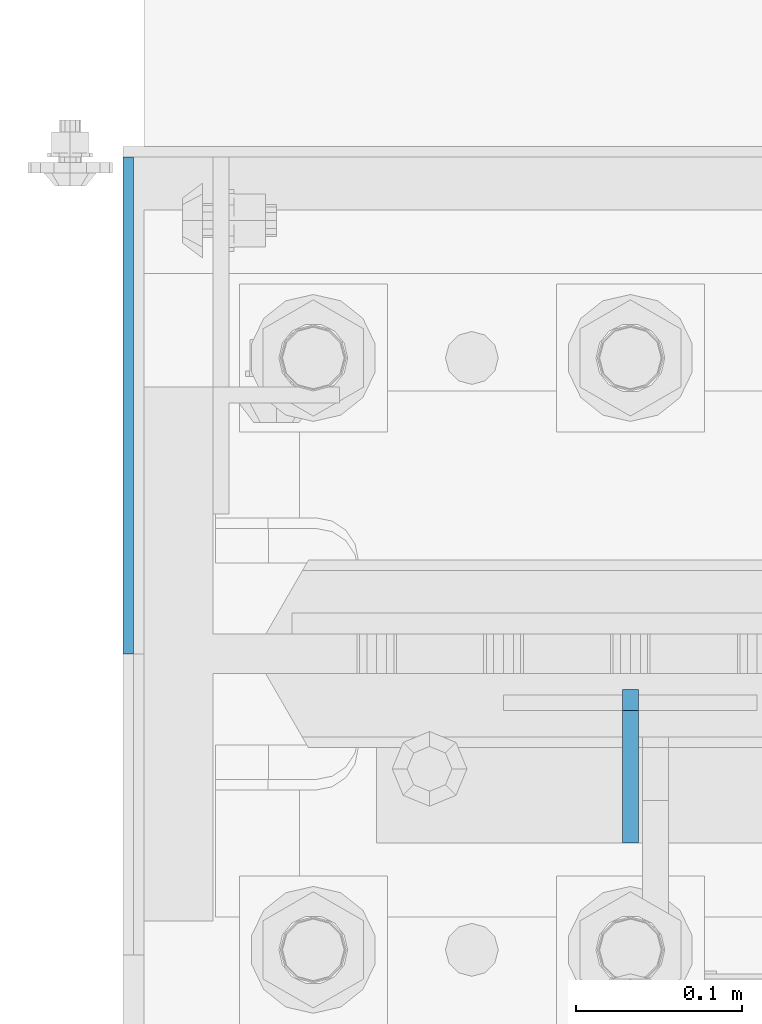
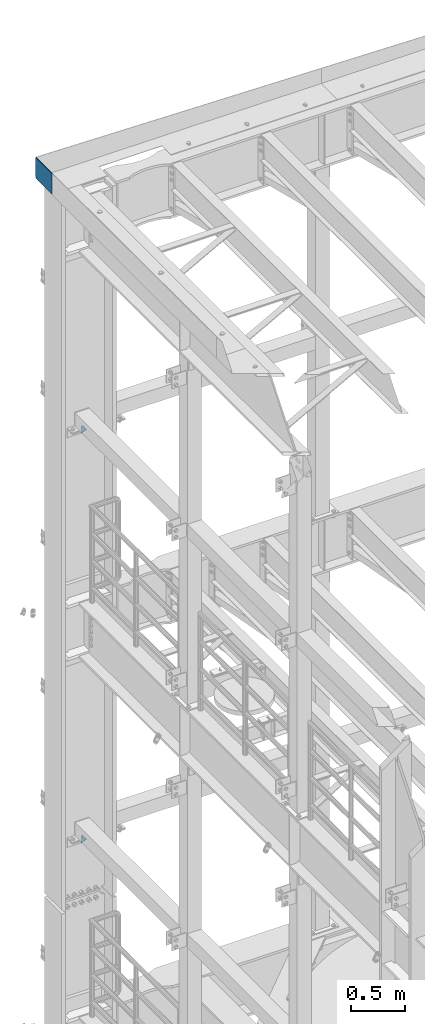
# One storey, part 1770 of 1876: 3 plates, 2 elements without a shape of their own.
"""IFC2X3 building model written with IfcOpenShell, lengths in millimetres."""

from ifc_helpers import new_model, si_unit, frame, origin_with_axes, place, context, subcontext, project, spatial, faceted_brep, material, type_object, element, aggregate, save


model = new_model("IFC2X3")

# Units and contexts
model_context = context("Model", 3, precision=1e-05, world=origin_with_axes())
body_context = subcontext(model_context, "Body", "Model", "MODEL_VIEW")
ifc_project = project(units=[si_unit("LENGTHUNIT", "METRE", prefix="MILLI"), si_unit("AREAUNIT", "SQUARE_METRE"), si_unit("VOLUMEUNIT", "CUBIC_METRE"), si_unit("MASSUNIT", "GRAM", prefix="KILO"), si_unit("TIMEUNIT", "SECOND"), si_unit("PLANEANGLEUNIT", "RADIAN"), si_unit("SOLIDANGLEUNIT", "STERADIAN"), si_unit("THERMODYNAMICTEMPERATUREUNIT", "DEGREE_CELSIUS"), si_unit("LUMINOUSINTENSITYUNIT", "LUMEN")], contexts=[model_context])

# Site, building, storey
site_placement = place(None, origin_with_axes())
site = spatial("IfcSite", under=ifc_project, at=site_placement, CompositionType="ELEMENT")
building_placement = place(site_placement, origin_with_axes())
building = spatial("IfcBuilding", under=site, at=building_placement, Name="Undefined", CompositionType="ELEMENT")
storey_placement = place(building_placement, origin_with_axes())
storey = spatial("IfcBuildingStorey", under=building, at=storey_placement, Name="Undefined", CompositionType="ELEMENT", Elevation=0.0)

# Assembly, plates
assembly_1_placement = place(storey_placement, origin_with_axes())
assembly_1 = element("IfcElementAssembly", 1, at=assembly_1_placement, inside=storey, Name="COLUMN", AssemblyPlace="NOTDEFINED", PredefinedType="RIGID_FRAME")
ifc_material = material(Name="STEEL/A36")
plate_type_1 = type_object("IfcPlateType", PredefinedType="NOTDEFINED")
plate_1_placement = place(assembly_1_placement, frame((0.0, 13602.4937494032, 19862.8), z_axis=(0.0, 0.707106781186548, 0.707106781186548), x_axis=(0.0, 0.707106781186548, -0.707106781186548)))
plate_1 = element("IfcPlate", 2, at=plate_1_placement, type_object=plate_type_1, material=ifc_material, Name="PLATE", context=body_context, shape_type="Brep", body=[
    faceted_brep([(0.0, -4.76249999999982, 0.0), (56.1266013136901, -4.76249999997708, 56.1266013135391), (56.1266013136883, 4.76250000002256, 56.1266013135428), (0.0, 4.76249999999982, 0.0), (74.0871132860975, -4.7624999999698, 56.1266013135246), (74.0871132860993, 4.76250000002983, 56.1266013135282), (130.213714599717, -4.76249999994707, -1.30967237055302e-10), (130.213714599715, 4.76250000005257, -1.23691279441118e-10)], [[[0, 1, 2, 3]], [[1, 4, 5, 2]], [[4, 6, 7, 5]], [[6, 0, 3, 7]], [[5, 7, 3, 2]], [[6, 4, 1, 0]]]),
])
plate_2_placement = place(assembly_1_placement, frame((0.0, 13602.4937494032, 15240.0), z_axis=(0.0, 0.707106781186548, 0.707106781186548), x_axis=(0.0, 0.707106781186548, -0.707106781186548)))
plate_2 = element("IfcPlate", 3, at=plate_2_placement, type_object=plate_type_1, material=ifc_material, Name="PLATE", context=body_context, shape_type="Brep", body=[
    faceted_brep([(0.0, -4.76249999999982, 0.0), (56.1266013136901, -4.76249999997708, 56.1266013135391), (56.1266013136883, 4.76250000002256, 56.1266013135428), (0.0, 4.76249999999982, 0.0), (74.0871132860975, -4.7624999999698, 56.1266013135246), (74.0871132860993, 4.76250000002983, 56.1266013135282), (130.213714599717, -4.76249999994707, -1.30967237055302e-10), (130.213714599715, 4.76250000005257, -1.23691279441118e-10)], [[[0, 1, 2, 3]], [[1, 4, 5, 2]], [[4, 6, 7, 5]], [[6, 0, 3, 7]], [[5, 7, 3, 2]], [[6, 4, 1, 0]]]),
])
aggregate(assembly_1, [plate_1, plate_2])

# Assembly, plate
assembly_2_placement = place(storey_placement, origin_with_axes())
assembly_2 = element("IfcElementAssembly", 4, at=assembly_2_placement, inside=storey, Name="BENT PLATE", AssemblyPlace="NOTDEFINED", PredefinedType="RIGID_FRAME")
plate_type_2 = type_object("IfcPlateType", PredefinedType="NOTDEFINED")
plate_3_placement = place(assembly_2_placement, frame((-301.625, 13716.0, 22561.5500038957), z_axis=(-1.22699999991482e-06, 7.19900000422058e-06, 0.999999999973334), x_axis=(0.0, 0.999999999968684, -7.91400000071008e-06)))
plate_3 = element("IfcPlate", 5, at=plate_3_placement, type_object=plate_type_2, material=ifc_material, Name="PLATE", context=body_context, shape_type="Brep", body=[
    faceted_brep([(-3.63797880709171e-12, -3.17499999999745, -3.63797880709171e-12), (-0.00168289586326864, -3.17500000000371, 233.757781982702), (-0.00168289586417814, 3.17499999999637, 233.757781982706), (3.63797880709171e-12, 3.17499999999836, 3.63797880709171e-12), (298.448608398525, -3.17500000000371, 233.759948730807), (298.448608398524, 3.17499999999637, 233.759948730811), (298.449816258273, -3.17500000000382, 19.0499992365294), (298.449816258277, 3.17499999999382, 19.0499992365367), (279.399951934936, -3.17499999999745, -1.81898940354586e-11), (279.39995193494, 3.17499999999836, -1.09139364212751e-11)], [[[0, 1, 2, 3]], [[1, 4, 5, 2]], [[4, 6, 7, 5]], [[6, 8, 9, 7]], [[8, 0, 3, 9]], [[5, 7, 9, 3, 2]], [[8, 6, 4, 1, 0]]]),
])
aggregate(assembly_2, [plate_3])

save(model, "model.ifc")
